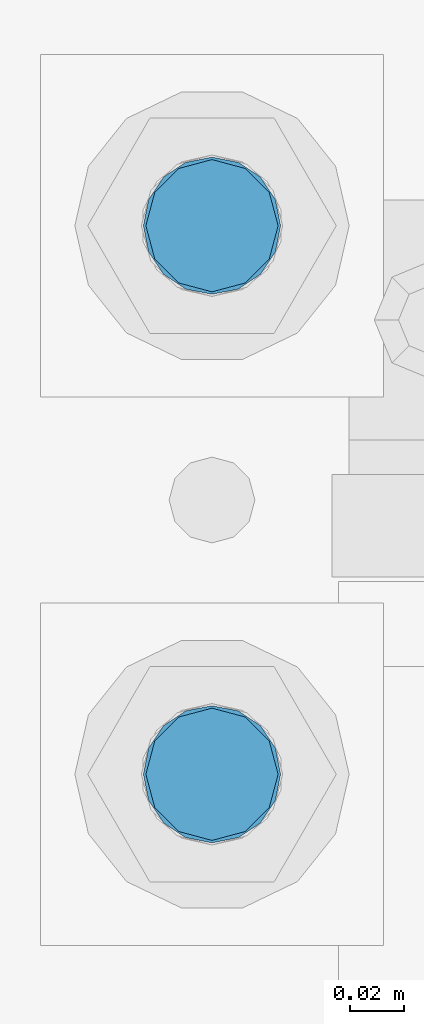
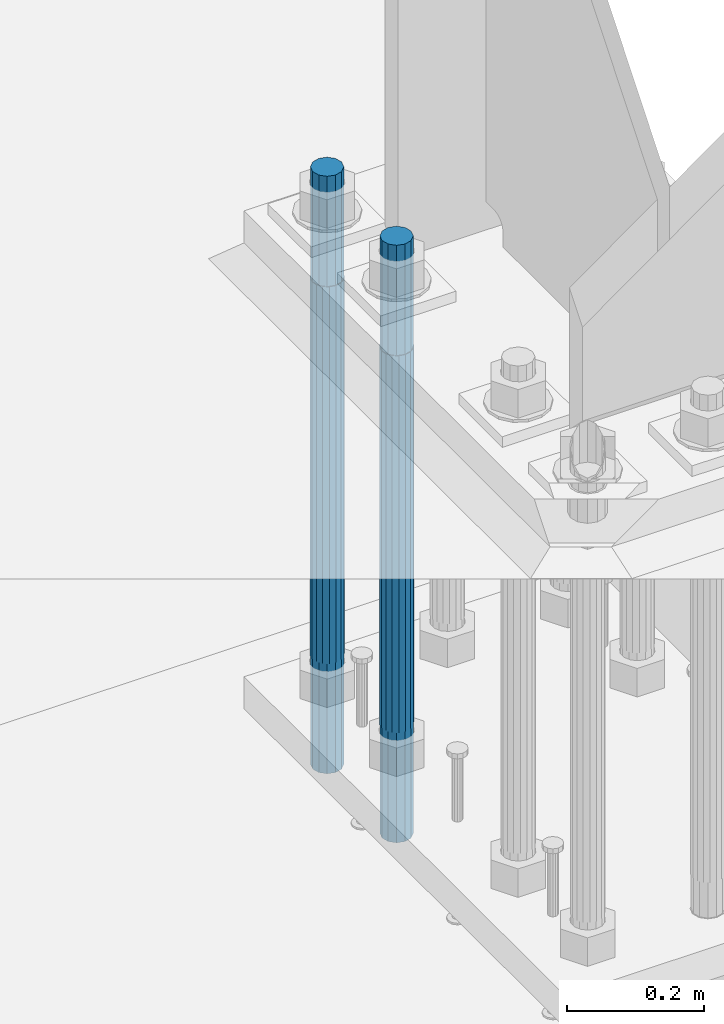
# One storey, part 691 of 1876: 2 columns, 1 element without a shape of its own.
"""IFC2X3 building model written with IfcOpenShell, lengths in millimetres."""

from ifc_helpers import new_model, si_unit, frame, origin_with_axes, place, context, subcontext, project, spatial, faceted_brep, material, type_object, element, aggregate, save


model = new_model("IFC2X3")

# Units and contexts
model_context = context("Model", 3, precision=1e-05, world=origin_with_axes())
body_context = subcontext(model_context, "Body", "Model", "MODEL_VIEW")
ifc_project = project(units=[si_unit("LENGTHUNIT", "METRE", prefix="MILLI"), si_unit("AREAUNIT", "SQUARE_METRE"), si_unit("VOLUMEUNIT", "CUBIC_METRE"), si_unit("MASSUNIT", "GRAM", prefix="KILO"), si_unit("TIMEUNIT", "SECOND"), si_unit("PLANEANGLEUNIT", "RADIAN"), si_unit("SOLIDANGLEUNIT", "STERADIAN"), si_unit("THERMODYNAMICTEMPERATUREUNIT", "DEGREE_CELSIUS"), si_unit("LUMINOUSINTENSITYUNIT", "LUMEN")], contexts=[model_context])

# Site, building, storey
site_placement = place(None, origin_with_axes())
site = spatial("IfcSite", under=ifc_project, at=site_placement, CompositionType="ELEMENT")
building_placement = place(site_placement, origin_with_axes())
building = spatial("IfcBuilding", under=site, at=building_placement, Name="Undefined", CompositionType="ELEMENT")
storey_placement = place(building_placement, origin_with_axes())
storey = spatial("IfcBuildingStorey", under=building, at=storey_placement, Name="Undefined", CompositionType="ELEMENT", Elevation=0.0)

# Assembly, columns
assembly_placement = place(storey_placement, origin_with_axes())
assembly = element("IfcElementAssembly", 1, at=assembly_placement, inside=storey, Name="TEMPLATE", AssemblyPlace="NOTDEFINED", PredefinedType="RIGID_FRAME")
ifc_material = material(Name="STEEL/F1554-GR.105")
column_type = type_object("IfcColumnType", PredefinedType="NOTDEFINED")
column_1_placement = place(assembly_placement, frame((7416.8, 1701.8, 0.0), z_axis=(0.0, -1.0, 0.0), x_axis=(0.0, 0.0, -1.0)))
column_1 = element("IfcColumn", 2, at=column_1_placement, type_object=column_type, material=ifc_material, Name="ANCHOR_BOLTS", context=body_context, shape_type="Brep", body=[
    faceted_brep([(-196.85, -21.217622392719, 12.25), (-196.85, -12.25, 21.2176223927188), (-196.85, 0.0, 24.5), (-196.85, 12.25, 21.2176223927188), (-196.85, 21.217622392719, 12.25), (-196.85, 24.5, 0.0), (-196.85, 21.217622392719, -12.25), (-196.85, 12.25, -21.2176223927188), (-196.85, 0.0, -24.5), (-196.85, -12.25, -21.2176223927188), (-196.85, -21.217622392719, -12.25), (-196.85, -24.5, 0.0), (0.0, 24.5, 0.0), (0.0, 21.217622392719, -12.25), (0.0, 12.25, -21.2176223927188), (0.0, 0.0, -24.5), (0.0, -12.25, -21.2176223927188), (0.0, -21.217622392719, -12.25), (0.0, -24.5, 0.0), (0.0, -21.217622392719, 12.25), (0.0, -12.25, 21.2176223927188), (0.0, 0.0, 24.5), (0.0, 12.25, 21.2176223927188), (0.0, 21.217622392719, 12.25), (0.0, -23.4665401257871, 9.7201591820733), (0.0, -17.9605122421381, 17.9605122421383), (0.0, -9.72015918207308, 23.4665401257867), (0.0, 0.0, 25.4000000000001), (0.0, 9.72015918207308, 23.4665401257867), (0.0, 17.9605122421381, 17.9605122421383), (0.0, 23.4665401257871, 9.7201591820733), (0.0, 25.3999996185339, 9.09494701772928e-13), (0.0, 23.4665401257871, -9.7201591820733), (0.0, 17.9605122421381, -17.9605122421383), (0.0, 9.72015918207308, -23.4665401257867), (0.0, 0.0, -25.4000000000001), (0.0, -9.72015918207308, -23.4665401257867), (0.0, -17.9605122421381, -17.9605122421383), (0.0, -23.4665401257871, -9.7201591820733), (0.0, -25.3999996185375, 0.0), (673.1, -25.3999999999996, 0.0), (673.1, -23.4665401257871, 9.7201591820733), (673.1, -17.9605122421381, 17.9605122421383), (673.1, -9.72015918207308, 23.4665401257867), (673.1, 0.0, 25.4000000000001), (673.1, 9.72015918207308, 23.4665401257867), (673.1, 17.9605122421381, 17.9605122421383), (673.1, 23.4665401257871, 9.7201591820733), (673.1, 25.3999999999996, 0.0), (673.1, 23.4665401257871, -9.7201591820733), (673.1, 17.9605122421381, -17.9605122421383), (673.1, 9.72015918207308, -23.4665401257867), (673.1, 0.0, -25.4000000000001), (673.1, -9.72015918207308, -23.4665401257867), (673.1, -17.9605122421381, -17.9605122421383), (673.1, -23.4665401257871, -9.7201591820733), (673.1, -12.25, 21.2176223927188), (673.1, 0.0, 24.5), (673.1, 12.25, 21.2176223927188), (673.1, 21.217622392719, 12.25), (673.1, 24.5, 0.0), (673.1, 21.217622392719, -12.25), (673.1, 12.25, -21.2176223927188), (673.1, 0.0, -24.5), (673.1, -12.25, -21.2176223927188), (673.1, -21.217622392719, -12.25), (673.1, -24.5, 0.0), (673.1, -21.217622392719, 12.25), (869.95, -12.25, -21.2176223927188), (869.95, 0.0, -24.5), (869.95, 12.25, -21.2176223927188), (869.95, 21.217622392719, -12.25), (869.95, 24.5, 0.0), (869.95, 21.217622392719, 12.25), (869.95, 12.25, 21.2176223927188), (869.95, 0.0, 24.5), (869.95, -12.25, 21.2176223927188), (869.95, -21.217622392719, 12.25), (869.95, -24.5, 0.0), (869.95, -21.217622392719, -12.25)], [[[0, 1, 2, 3, 4, 5, 6, 7, 8, 9, 10, 11]], [[6, 5, 12, 13]], [[7, 6, 13, 14]], [[8, 7, 14, 15]], [[9, 8, 15, 16]], [[10, 9, 16, 17]], [[11, 10, 17, 18]], [[0, 11, 18, 19]], [[1, 0, 19, 20]], [[2, 1, 20, 21]], [[3, 2, 21, 22]], [[4, 3, 22, 23]], [[5, 4, 23, 12]], [[24, 25, 26, 27, 28, 29, 30, 31, 32, 33, 34, 35, 36, 37, 38, 39], [22, 21, 20, 19, 18, 17, 16, 15, 14, 13, 12, 23]], [[24, 39, 40, 41]], [[25, 24, 41, 42]], [[26, 25, 42, 43]], [[27, 26, 43, 44]], [[28, 27, 44, 45]], [[29, 28, 45, 46]], [[30, 29, 46, 47]], [[31, 30, 47, 48]], [[32, 31, 48, 49]], [[33, 32, 49, 50]], [[34, 33, 50, 51]], [[35, 34, 51, 52]], [[36, 35, 52, 53]], [[37, 36, 53, 54]], [[38, 37, 54, 55]], [[39, 38, 55, 40]], [[54, 53, 52, 51, 50, 49, 48, 47, 46, 45, 44, 43, 42, 41, 40, 55], [56, 57, 58, 59, 60, 61, 62, 63, 64, 65, 66, 67]], [[68, 69, 70, 71, 72, 73, 74, 75, 76, 77, 78, 79]], [[76, 75, 57, 56]], [[77, 76, 56, 67]], [[78, 77, 67, 66]], [[79, 78, 66, 65]], [[68, 79, 65, 64]], [[69, 68, 64, 63]], [[70, 69, 63, 62]], [[71, 70, 62, 61]], [[72, 71, 61, 60]], [[73, 72, 60, 59]], [[74, 73, 59, 58]], [[75, 74, 58, 57]]]),
])
column_2_placement = place(assembly_placement, frame((7416.8, 1905.0, 0.0), z_axis=(0.0, -1.0, 0.0), x_axis=(0.0, 0.0, -1.0)))
column_2 = element("IfcColumn", 3, at=column_2_placement, type_object=column_type, material=ifc_material, Name="ANCHOR_BOLTS", context=body_context, shape_type="Brep", body=[
    faceted_brep([(-196.85, -21.217622392719, 12.25), (-196.85, -12.25, 21.2176223927188), (-196.85, 0.0, 24.5), (-196.85, 12.25, 21.2176223927188), (-196.85, 21.217622392719, 12.25), (-196.85, 24.5, 0.0), (-196.85, 21.217622392719, -12.25), (-196.85, 12.25, -21.2176223927188), (-196.85, 0.0, -24.5), (-196.85, -12.25, -21.2176223927188), (-196.85, -21.217622392719, -12.25), (-196.85, -24.5, 0.0), (0.0, 24.5, 0.0), (0.0, 21.217622392719, -12.25), (0.0, 12.25, -21.2176223927188), (0.0, 0.0, -24.5), (0.0, -12.25, -21.2176223927188), (0.0, -21.217622392719, -12.25), (0.0, -24.5, 0.0), (0.0, -21.217622392719, 12.25), (0.0, -12.25, 21.2176223927188), (0.0, 0.0, 24.5), (0.0, 12.25, 21.2176223927188), (0.0, 21.217622392719, 12.25), (0.0, -23.4665401257871, 9.7201591820733), (0.0, -17.9605122421381, 17.9605122421383), (0.0, -9.72015918207308, 23.4665401257867), (0.0, 0.0, 25.4000000000001), (0.0, 9.72015918207308, 23.4665401257867), (0.0, 17.9605122421381, 17.9605122421383), (0.0, 23.4665401257871, 9.7201591820733), (0.0, 25.3999996185339, 9.09494701772928e-13), (0.0, 23.4665401257871, -9.7201591820733), (0.0, 17.9605122421381, -17.9605122421383), (0.0, 9.72015918207308, -23.4665401257867), (0.0, 0.0, -25.4000000000001), (0.0, -9.72015918207308, -23.4665401257867), (0.0, -17.9605122421381, -17.9605122421383), (0.0, -23.4665401257871, -9.7201591820733), (0.0, -25.3999996185375, 0.0), (673.1, -25.3999999999996, 0.0), (673.1, -23.4665401257871, 9.7201591820733), (673.1, -17.9605122421381, 17.9605122421383), (673.1, -9.72015918207308, 23.4665401257867), (673.1, 0.0, 25.4000000000001), (673.1, 9.72015918207308, 23.4665401257867), (673.1, 17.9605122421381, 17.9605122421383), (673.1, 23.4665401257871, 9.7201591820733), (673.1, 25.3999999999996, 0.0), (673.1, 23.4665401257871, -9.7201591820733), (673.1, 17.9605122421381, -17.9605122421383), (673.1, 9.72015918207308, -23.4665401257867), (673.1, 0.0, -25.4000000000001), (673.1, -9.72015918207308, -23.4665401257867), (673.1, -17.9605122421381, -17.9605122421383), (673.1, -23.4665401257871, -9.7201591820733), (673.1, -12.25, 21.2176223927188), (673.1, 0.0, 24.5), (673.1, 12.25, 21.2176223927188), (673.1, 21.217622392719, 12.25), (673.1, 24.5, 0.0), (673.1, 21.217622392719, -12.25), (673.1, 12.25, -21.2176223927188), (673.1, 0.0, -24.5), (673.1, -12.25, -21.2176223927188), (673.1, -21.217622392719, -12.25), (673.1, -24.5, 0.0), (673.1, -21.217622392719, 12.25), (869.95, -12.25, -21.2176223927188), (869.95, 0.0, -24.5), (869.95, 12.25, -21.2176223927188), (869.95, 21.217622392719, -12.25), (869.95, 24.5, 0.0), (869.95, 21.217622392719, 12.25), (869.95, 12.25, 21.2176223927188), (869.95, 0.0, 24.5), (869.95, -12.25, 21.2176223927188), (869.95, -21.217622392719, 12.25), (869.95, -24.5, 0.0), (869.95, -21.217622392719, -12.25)], [[[0, 1, 2, 3, 4, 5, 6, 7, 8, 9, 10, 11]], [[6, 5, 12, 13]], [[7, 6, 13, 14]], [[8, 7, 14, 15]], [[9, 8, 15, 16]], [[10, 9, 16, 17]], [[11, 10, 17, 18]], [[0, 11, 18, 19]], [[1, 0, 19, 20]], [[2, 1, 20, 21]], [[3, 2, 21, 22]], [[4, 3, 22, 23]], [[5, 4, 23, 12]], [[24, 25, 26, 27, 28, 29, 30, 31, 32, 33, 34, 35, 36, 37, 38, 39], [22, 21, 20, 19, 18, 17, 16, 15, 14, 13, 12, 23]], [[24, 39, 40, 41]], [[25, 24, 41, 42]], [[26, 25, 42, 43]], [[27, 26, 43, 44]], [[28, 27, 44, 45]], [[29, 28, 45, 46]], [[30, 29, 46, 47]], [[31, 30, 47, 48]], [[32, 31, 48, 49]], [[33, 32, 49, 50]], [[34, 33, 50, 51]], [[35, 34, 51, 52]], [[36, 35, 52, 53]], [[37, 36, 53, 54]], [[38, 37, 54, 55]], [[39, 38, 55, 40]], [[54, 53, 52, 51, 50, 49, 48, 47, 46, 45, 44, 43, 42, 41, 40, 55], [56, 57, 58, 59, 60, 61, 62, 63, 64, 65, 66, 67]], [[68, 69, 70, 71, 72, 73, 74, 75, 76, 77, 78, 79]], [[76, 75, 57, 56]], [[77, 76, 56, 67]], [[78, 77, 67, 66]], [[79, 78, 66, 65]], [[68, 79, 65, 64]], [[69, 68, 64, 63]], [[70, 69, 63, 62]], [[71, 70, 62, 61]], [[72, 71, 61, 60]], [[73, 72, 60, 59]], [[74, 73, 59, 58]], [[75, 74, 58, 57]]]),
])
aggregate(assembly, [column_1, column_2])

save(model, "model.ifc")
